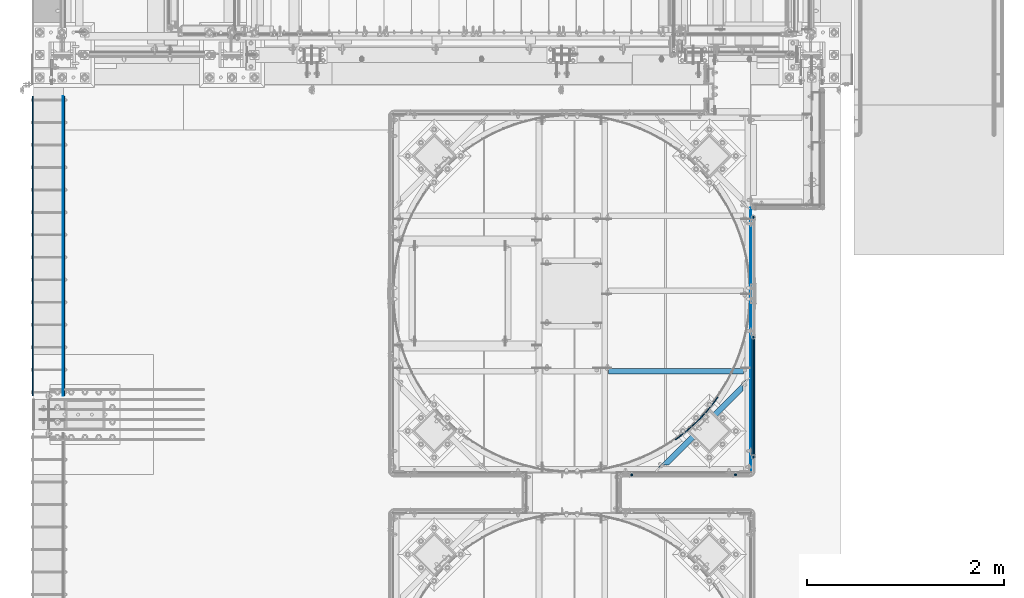
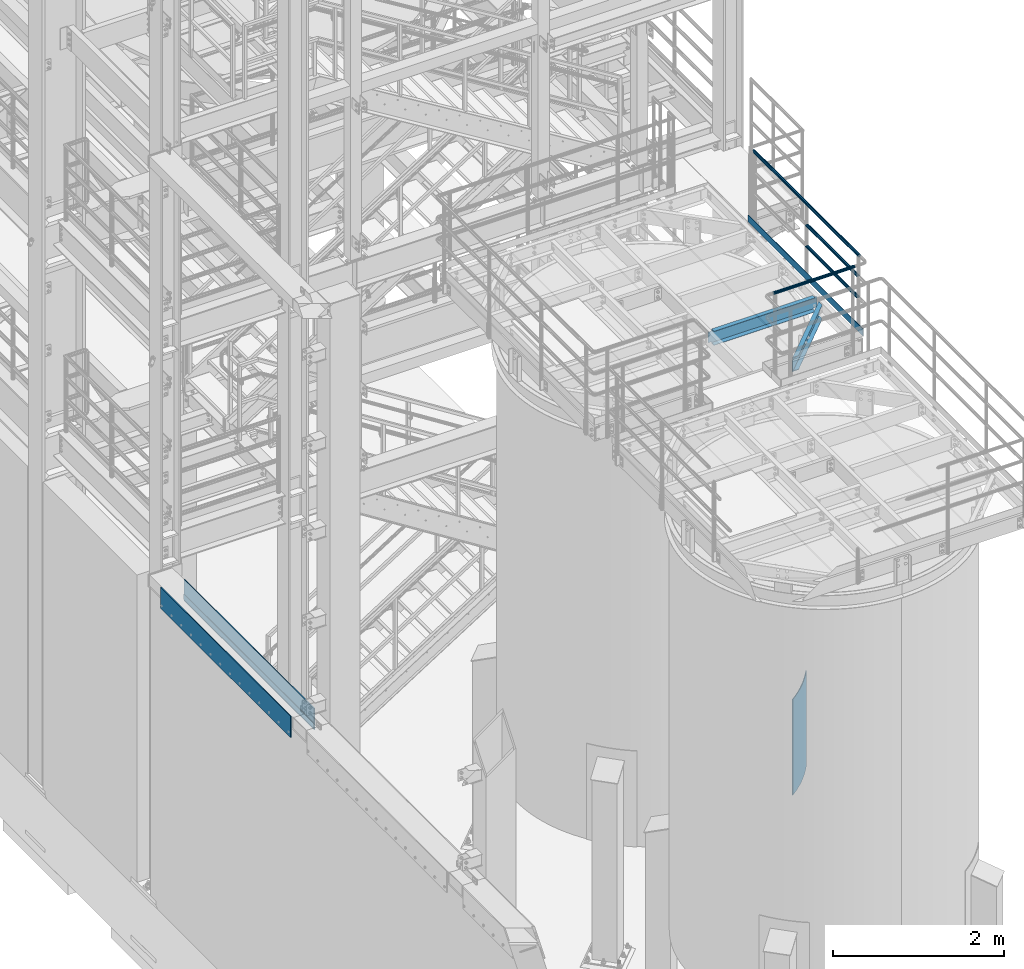
# One storey, part 928 of 1876: 11 beams, 7 elements without a shape of their own.
"""IFC2X3 building model written with IfcOpenShell, lengths in millimetres."""

from ifc_helpers import new_model, si_unit, frame, origin_with_axes, place, context, subcontext, project, spatial, faceted_brep, material, type_object, element, aggregate, save


model = new_model("IFC2X3")

# Units and contexts
model_context = context("Model", 3, precision=1e-05, world=origin_with_axes())
body_context = subcontext(model_context, "Body", "Model", "MODEL_VIEW")
ifc_project = project(units=[si_unit("LENGTHUNIT", "METRE", prefix="MILLI"), si_unit("AREAUNIT", "SQUARE_METRE"), si_unit("VOLUMEUNIT", "CUBIC_METRE"), si_unit("MASSUNIT", "GRAM", prefix="KILO"), si_unit("TIMEUNIT", "SECOND"), si_unit("PLANEANGLEUNIT", "RADIAN"), si_unit("SOLIDANGLEUNIT", "STERADIAN"), si_unit("THERMODYNAMICTEMPERATUREUNIT", "DEGREE_CELSIUS"), si_unit("LUMINOUSINTENSITYUNIT", "LUMEN")], contexts=[model_context])

# Site, building, storey
site_placement = place(None, origin_with_axes())
site = spatial("IfcSite", under=ifc_project, at=site_placement, CompositionType="ELEMENT")
building_placement = place(site_placement, origin_with_axes())
building = spatial("IfcBuilding", under=site, at=building_placement, Name="Undefined", CompositionType="ELEMENT")
storey_placement = place(building_placement, origin_with_axes())
storey = spatial("IfcBuildingStorey", under=building, at=storey_placement, Name="Undefined", CompositionType="ELEMENT", Elevation=0.0)

# Assembly, beam
assembly_1_placement = place(storey_placement, origin_with_axes())
assembly_1 = element("IfcElementAssembly", 1, at=assembly_1_placement, inside=storey, Name="PLATE", AssemblyPlace="NOTDEFINED", PredefinedType="RIGID_FRAME")
ifc_material_1 = material(Name="STEEL/A36")
beam_type_1 = type_object("IfcBeamType", PredefinedType="NOTDEFINED")
beam_1_placement = place(assembly_1_placement, frame((8.73150000000262, -7531.1, 4432.3), z_axis=(0.0, 0.0, 1.0), x_axis=(0.0, -1.0, 0.0)))
beam_1 = element("IfcBeam", 2, at=beam_1_placement, type_object=beam_type_1, material=ifc_material_1, Name="PLATE", context=body_context, shape_type="Brep", body=[
    faceted_brep([(0.0, 3.969, -38.1000000000004), (0.0, 3.969, 38.1000000000004), (3048.0, 3.969, 38.1000000000004), (3048.0, 3.969, -38.1000000000004), (0.0, -3.969, 38.1000000000004), (3048.0, -3.969, 38.1000000000004), (0.0, -3.969, -38.1000000000004), (3048.0, -3.969, -38.1000000000004)], [[[0, 1, 2, 3]], [[1, 4, 5, 2]], [[4, 6, 7, 5]], [[6, 0, 3, 7]], [[5, 7, 3, 2]], [[6, 4, 1, 0]]]),
])

assembly_2_placement = place(storey_placement, origin_with_axes())
assembly_2 = element("IfcElementAssembly", 3, at=assembly_2_placement, inside=storey, Name="BEAM", AssemblyPlace="NOTDEFINED", PredefinedType="RIGID_FRAME")
beam_type_2 = type_object("IfcBeamType", PredefinedType="NOTDEFINED")
beam_2_placement = place(assembly_2_placement, frame((-298.449999999997, -7531.1, 4521.2), z_axis=(0.0, 0.0, 1.0), x_axis=(0.0, -1.0, 0.0)))
beam_2 = element("IfcBeam", 4, at=beam_2_placement, type_object=beam_type_2, material=ifc_material_1, Name="PLATE", context=body_context, shape_type="Brep", body=[
    faceted_brep([(0.0, 6.35000000000002, -152.4), (0.0, 6.35000000000002, 152.4), (3048.00000152588, 6.35000000000002, 152.4), (3048.00000152588, 6.35000000000002, -152.4), (0.0, -6.35000000000002, 152.4), (3048.00000152588, -6.35000000000002, 152.4), (0.0, -6.35000000000002, -152.4), (3048.00000152588, -6.35000000000002, -152.4)], [[[0, 1, 2, 3]], [[1, 4, 5, 2]], [[4, 6, 7, 5]], [[6, 0, 3, 7]], [[5, 7, 3, 2]], [[6, 4, 1, 0]]]),
])
aggregate(assembly_2, [beam_2])

# Beam
beam_3_placement = place(assembly_1_placement, frame((19.0500000000009, -7531.1, 4521.2), z_axis=(0.0, 0.0, 1.0), x_axis=(0.0, -1.0, 0.0)))
beam_3 = element("IfcBeam", 5, at=beam_3_placement, type_object=beam_type_2, material=ifc_material_1, Name="PLATE", context=body_context, shape_type="Brep", body=[
    faceted_brep([(0.0, 6.35000000000002, -152.4), (0.0, 6.35000000000002, 152.4), (3048.00000152588, 6.35000000000002, 152.4), (3048.00000152588, 6.35000000000002, -152.4), (0.0, -6.35000000000002, 152.4), (3048.00000152588, -6.35000000000002, 152.4), (0.0, -6.35000000000002, -152.4), (3048.00000152588, -6.35000000000002, -152.4)], [[[0, 1, 2, 3]], [[1, 4, 5, 2]], [[4, 6, 7, 5]], [[6, 0, 3, 7]], [[5, 7, 3, 2]], [[6, 4, 1, 0]]]),
])

aggregate(assembly_1, [beam_1, beam_3])

# Assembly, beam
assembly_3_placement = place(storey_placement, origin_with_axes())
assembly_3 = element("IfcElementAssembly", 6, at=assembly_3_placement, inside=storey, Name="HANDRAIL", AssemblyPlace="NOTDEFINED", PredefinedType="RIGID_FRAME")
ifc_material_2 = material()
beam_type_3 = type_object("IfcBeamType", Name="PIPE1-1/4STD", PredefinedType="NOTDEFINED")
beam_4_placement = place(assembly_3_placement, frame((5770.12274593762, -11381.1963554687, 9090.025), z_axis=(0.0, 0.0, -1.0), x_axis=(1.0, 0.0, 0.0)))
beam_4 = element("IfcBeam", 7, at=beam_4_placement, type_object=beam_type_3, material=ifc_material_2, Name="HANDRAIL", ObjectType="PIPE1-1/4STD", context=body_context, shape_type="Brep", body=[
    faceted_brep([(0.0, -17.5259999999998, 0.0), (0.0, -15.1779612267264, 8.76300000000083), (1096.264, -15.1779612267255, 8.76300000000083), (1096.264, -17.5259999999998, 0.0), (0.0, -8.76299999999992, 15.1779612267255), (1096.264, -8.76300000000083, 15.1779612267255), (0.0, 0.0, 17.5259999999998), (1096.264, 0.0, 17.5259999999998), (0.0, 8.76299999999992, 15.1779612267255), (1096.264, 8.76300000000083, 15.1779612267255), (0.0, 15.1779612267264, 8.76300000000083), (1096.264, 15.1779612267255, 8.76300000000083), (0.0, 17.5259999999998, 0.0), (1096.264, 17.5259999999998, 0.0), (0.0, 15.1779612267264, -8.76300000000083), (1096.264, 15.1779612267255, -8.76300000000083), (0.0, 8.76299999999992, -15.1779612267255), (1096.264, 8.76300000000083, -15.1779612267255), (0.0, 0.0, -17.5259999999998), (1096.264, 0.0, -17.5259999999998), (0.0, -8.76299999999992, -15.1779612267255), (1096.264, -8.76300000000083, -15.1779612267255), (0.0, -15.1779612267264, -8.76300000000083), (1096.264, -15.1779612267255, -8.76300000000083), (9.09494701772928e-13, -21.0820000000003, 0.0), (0.0, -18.2575475625836, -10.5409999999993), (1096.264, -18.2575475625836, -10.5409999999993), (1096.264, -21.0820000000003, 0.0), (0.0, -10.5410000000002, -18.2575475625836), (1096.264, -10.5409999999993, -18.2575475625836), (-4.28826751885936e-09, 0.0, -21.0820000000003), (1096.264, 0.0, -21.0820000000003), (0.0, 10.5410000000002, -18.2575475625836), (1096.264, 10.5409999999993, -18.2575475625836), (0.0, 18.2575475625836, -10.5409999999993), (1096.264, 18.2575475625836, -10.5409999999993), (9.09494701772928e-13, 21.0820000000003, 0.0), (1096.264, 21.0820000000003, 0.0), (0.0, 18.2575475625836, 10.5409999999993), (1096.264, 18.2575475625836, 10.5409999999993), (0.0, 10.5410000000002, 18.2575475625836), (1096.264, 10.5409999999993, 18.2575475625836), (0.0, 0.0, 21.0820000000003), (1096.264, 0.0, 21.0820000000003), (0.0, -10.5410000000002, 18.2575475625836), (1096.264, -10.5409999999993, 18.2575475625836), (0.0, -18.2575475625836, 10.5409999999993), (1096.264, -18.2575475625836, 10.5409999999993)], [[[0, 1, 2, 3]], [[1, 4, 5, 2]], [[4, 6, 7, 5]], [[6, 8, 9, 7]], [[8, 10, 11, 9]], [[10, 12, 13, 11]], [[12, 14, 15, 13]], [[14, 16, 17, 15]], [[16, 18, 19, 17]], [[18, 20, 21, 19]], [[20, 22, 23, 21]], [[22, 0, 3, 23]], [[24, 25, 26, 27]], [[25, 28, 29, 26]], [[28, 30, 31, 29]], [[30, 32, 33, 31]], [[32, 34, 35, 33]], [[34, 36, 37, 35]], [[36, 38, 39, 37]], [[38, 40, 41, 39]], [[40, 42, 43, 41]], [[42, 44, 45, 43]], [[44, 46, 47, 45]], [[46, 24, 27, 47]], [[29, 31, 33, 35, 37, 39, 41, 43, 45, 47, 27, 26], [5, 7, 9, 11, 13, 15, 17, 19, 21, 23, 3, 2]], [[46, 44, 42, 40, 38, 36, 34, 32, 30, 28, 25, 24], [22, 20, 18, 16, 14, 12, 10, 8, 6, 4, 1, 0]]]),
])
aggregate(assembly_3, [beam_4])

# Assembly, beams
assembly_4_placement = place(storey_placement, origin_with_axes())
assembly_4 = element("IfcElementAssembly", 8, at=assembly_4_placement, inside=storey, Name="HANDRAIL", AssemblyPlace="NOTDEFINED", PredefinedType="RIGID_FRAME")
beam_5_placement = place(assembly_4_placement, frame((7025.13388293519, -11201.3643554687, 8480.425), z_axis=(0.0, 0.0, 1.0), x_axis=(0.0, 1.0, 0.0)))
beam_5 = element("IfcBeam", 9, at=beam_5_placement, type_object=beam_type_3, material=ifc_material_2, Name="RAIL", ObjectType="PIPE1-1/4STD", context=body_context, shape_type="Brep", body=[
    faceted_brep([(1200.94245243742, -10.5409999999993, 18.2575475625836), (1200.94245243742, -10.5409999999993, 13.3999612267253), (1200.46603877327, -8.76300000000083, 15.1779612267255), (1198.118, 0.0, 17.5259999999998), (1198.118, 0.0, 21.0820000000003), (1200.46603877327, 8.76300000000083, 15.1779612267255), (1200.94245243742, 10.5409999999993, 13.3999612267253), (1200.94245243742, 10.5409999999993, 18.2575475625836), (1219.2, 21.0820000000003, 0.0), (1208.659, 18.2575475625836, 10.5409999999993), (1208.659, 18.2575475625836, -10.5409999999993), (1205.57941366414, 15.1779612267255, 8.76300000000083), (1207.92745243742, 17.5259999999998, 0.0), (1205.57941366414, 15.1779612267255, -8.76300000000083), (1200.94245243742, 10.5409999999993, -13.3999612267253), (1200.94245243742, 10.5409999999993, -18.2575475625836), (1200.46603877327, 8.76300000000083, -15.1779612267255), (1198.118, 0.0, -17.5259999999998), (1198.118, 0.0, -21.0820000000003), (1200.94245243742, -10.5409999999993, -13.3999612267253), (1200.94245243742, -10.5409999999993, -18.2575475625836), (1200.46603877327, -8.76300000000083, -15.1779612267255), (1219.2, -21.0820000000003, 0.0), (1208.659, -18.2575475625836, -10.5409999999993), (1208.659, -18.2575475625836, 10.5409999999993), (1205.57941366414, -15.1779612267255, -8.76300000000083), (1207.92745243742, -17.5259999999998, 0.0), (1205.57941366414, -15.1779612267255, 8.76300000000083), (10.5409999957128, -18.2575475672238, -10.5409999999993), (18.2575475625817, -10.5410000000011, -18.2575475625836), (9.09494701772928e-13, 21.0820000000003, 0.0), (10.5409999957128, 18.2575475579433, -10.5409999999993), (10.5409999999983, 18.2575475625836, 10.5410000000011), (18.2575475625817, 10.5409999999993, 18.2575475625836), (21.0819999999985, 1.81898940354586e-12, 21.0820000000003), (18.2575475625817, 10.5409999999993, -18.2575475625836), (21.0819999999985, 0.0, -21.0819999999985), (21.0819999999985, 0.0, -17.5259999999998), (18.2575475625817, -10.5409999999974, -13.3999612267271), (18.7339612267233, -8.76300000000083, -15.1779612267255), (18.7339612267251, 8.76299999999901, -15.1779612267255), (18.2575475625817, 10.5410000000011, -13.3999612267235), (13.6205863358573, 15.1779612267255, -8.76299999999901), (11.2725475625839, 17.5259999999998, 0.0), (13.6205863358573, 15.1779612267255, 8.76300000000083), (18.2575475625817, 10.5410000000011, 13.3999612267253), (18.7339612267251, 8.76299999999901, 15.1779612267273), (21.0819999999985, 1.81898940354586e-12, 17.5259999999998), (18.7339612267233, -8.76300000000083, 15.1779612267273), (18.2575475625817, -10.5409999999974, 13.3999612267289), (18.2575475625817, -10.5410000000011, 18.2575475625836), (10.5409999999983, -18.2575475625836, 10.5410000000011), (9.09494701772928e-13, -21.0820000000003, 0.0), (13.6205863358537, -15.1779612267255, 8.76300000000083), (11.2725475625793, -17.5259999999998, 0.0), (13.6205863358537, -15.1779612267255, -8.76299999999901)], [[[0, 1, 2, 3, 4]], [[4, 3, 5, 6, 7]], [[8, 9, 10]], [[7, 6, 11, 12, 13, 14, 15, 10, 9]], [[16, 17, 18, 15, 14]], [[19, 20, 18, 17, 21]], [[22, 23, 24]], [[24, 23, 20, 19, 25, 26, 27, 1, 0]], [[28, 29, 20, 23]], [[30, 31, 32]], [[33, 34, 4, 7]], [[32, 33, 7, 9]], [[30, 32, 9, 8]], [[31, 30, 8, 10]], [[35, 31, 10, 15]], [[36, 35, 15, 18]], [[29, 36, 18, 20]], [[37, 36, 29, 38, 39]], [[40, 41, 35, 36, 37]], [[32, 31, 35, 41, 42, 43, 44, 45, 33]], [[33, 45, 46, 47, 34]], [[34, 47, 48, 49, 50]], [[34, 50, 0, 4]], [[50, 51, 24, 0]], [[51, 52, 22, 24]], [[52, 28, 23, 22]], [[51, 28, 52]], [[50, 49, 53, 54, 55, 38, 29, 28, 51]], [[55, 54, 26, 25]], [[21, 39, 38, 55, 25, 19]], [[37, 39, 21, 17]], [[40, 37, 17, 16]], [[42, 41, 40, 16, 14, 13]], [[43, 42, 13, 12]], [[44, 43, 12, 11]], [[5, 46, 45, 44, 11, 6]], [[47, 46, 5, 3]], [[48, 47, 3, 2]], [[53, 49, 48, 2, 1, 27]], [[54, 53, 27, 26]]]),
])
beam_6_placement = place(assembly_4_placement, frame((7025.13388293519, -9982.16435546873, 8785.225), z_axis=(0.0, 0.0, -1.0), x_axis=(0.0, -1.0, 0.0)))
beam_6 = element("IfcBeam", 10, at=beam_6_placement, type_object=beam_type_3, material=ifc_material_2, Name="RAIL", ObjectType="PIPE1-1/4STD", context=body_context, shape_type="Brep", body=[
    faceted_brep([(9.09494701772928e-13, 21.0820000000003, 0.0), (10.5409999957128, 18.2575475579433, -10.5409999999993), (10.5409999999983, 18.2575475625836, 10.5410000000011), (10.5409999999983, -18.2575475625836, 10.5410000000011), (10.5409999957128, -18.2575475672238, -10.5409999999993), (9.09494701772928e-13, -21.0820000000003, 0.0), (18.2575475625817, -10.5410000000011, 18.2575475625836), (18.2575475625817, -10.5409999999974, 13.3999612267289), (13.6205863358537, -15.1779612267255, 8.76300000000083), (11.2725475625793, -17.5259999999998, 0.0), (13.6205863358537, -15.1779612267255, -8.76299999999901), (18.2575475625817, -10.5409999999974, -13.3999612267271), (18.2575475625817, -10.5410000000011, -18.2575475625836), (21.0819999999985, 0.0, -17.5259999999998), (21.0819999999985, 0.0, -21.0819999999985), (18.7339612267233, -8.76300000000083, -15.1779612267255), (18.7339612267251, 8.76299999999901, -15.1779612267255), (18.2575475625817, 10.5410000000011, -13.3999612267235), (18.2575475625817, 10.5409999999993, -18.2575475625836), (13.6205863358573, 15.1779612267255, -8.76299999999901), (11.2725475625839, 17.5259999999998, 0.0), (13.6205863358573, 15.1779612267255, 8.76300000000083), (18.2575475625817, 10.5410000000011, 13.3999612267253), (18.2575475625817, 10.5409999999993, 18.2575475625836), (18.7339612267251, 8.76299999999901, 15.1779612267273), (21.0819999999985, 1.81898940354586e-12, 17.5259999999998), (21.0819999999985, 1.81898940354586e-12, 21.0820000000003), (18.7339612267233, -8.76300000000083, 15.1779612267273), (1219.2, 21.0820000000003, 0.0), (1208.659, 18.2575475625836, -10.5409999999993), (1200.94245243742, 10.5409999999993, -18.2575475625836), (1219.2, -21.0820000000003, 0.0), (1208.659, -18.2575475625836, -10.5409999999993), (1208.659, -18.2575475625836, 10.5409999999993), (1200.94245243742, -10.5409999999993, 18.2575475625836), (1200.94245243742, -10.5409999999993, -18.2575475625836), (1198.118, 0.0, -21.0820000000003), (1200.46603877327, 8.76300000000083, -15.1779612267255), (1198.118, 0.0, -17.5259999999998), (1200.94245243742, 10.5409999999993, -13.3999612267253), (1200.94245243742, -10.5409999999993, -13.3999612267253), (1200.46603877327, -8.76300000000083, -15.1779612267255), (1205.57941366414, -15.1779612267255, -8.76300000000083), (1207.92745243742, -17.5259999999998, 0.0), (1205.57941366414, -15.1779612267255, 8.76300000000083), (1200.94245243742, -10.5409999999993, 13.3999612267253), (1200.46603877327, -8.76300000000083, 15.1779612267255), (1198.118, 0.0, 17.5259999999998), (1198.118, 0.0, 21.0820000000003), (1200.94245243742, 10.5409999999993, 18.2575475625836), (1208.659, 18.2575475625836, 10.5409999999993), (1200.94245243742, 10.5409999999993, 13.3999612267253), (1205.57941366414, 15.1779612267255, 8.76300000000083), (1207.92745243742, 17.5259999999998, 0.0), (1205.57941366414, 15.1779612267255, -8.76300000000083), (1200.46603877327, 8.76300000000083, 15.1779612267255)], [[[0, 1, 2]], [[3, 4, 5]], [[6, 7, 8, 9, 10, 11, 12, 4, 3]], [[13, 14, 12, 11, 15]], [[16, 17, 18, 14, 13]], [[2, 1, 18, 17, 19, 20, 21, 22, 23]], [[23, 22, 24, 25, 26]], [[26, 25, 27, 7, 6]], [[1, 0, 28, 29]], [[18, 1, 29, 30]], [[31, 32, 33]], [[6, 3, 33, 34]], [[3, 5, 31, 33]], [[5, 4, 32, 31]], [[4, 12, 35, 32]], [[12, 14, 36, 35]], [[14, 18, 30, 36]], [[37, 38, 36, 30, 39]], [[40, 35, 36, 38, 41]], [[33, 32, 35, 40, 42, 43, 44, 45, 34]], [[34, 45, 46, 47, 48]], [[26, 6, 34, 48]], [[2, 23, 49, 50]], [[23, 26, 48, 49]], [[0, 2, 50, 28]], [[28, 50, 29]], [[49, 51, 52, 53, 54, 39, 30, 29, 50]], [[48, 47, 55, 51, 49]], [[25, 24, 55, 47]], [[55, 24, 22, 21, 52, 51]], [[21, 20, 53, 52]], [[20, 19, 54, 53]], [[19, 17, 16, 37, 39, 54]], [[16, 13, 38, 37]], [[13, 15, 41, 38]], [[41, 15, 11, 10, 42, 40]], [[10, 9, 43, 42]], [[9, 8, 44, 43]], [[8, 7, 27, 46, 45, 44]], [[27, 25, 47, 46]]]),
])
beam_7_placement = place(assembly_4_placement, frame((7025.13388293519, -8741.88235546873, 9090.025), z_axis=(0.0, 0.0, -1.0), x_axis=(0.0, -1.0, 0.0)))
beam_7 = element("IfcBeam", 11, at=beam_7_placement, type_object=beam_type_3, material=ifc_material_2, Name="HANDRAIL", ObjectType="PIPE1-1/4STD", context=body_context, shape_type="Brep", body=[
    faceted_brep([(21.0819999957121, -17.5260000092794, 0.0), (29.8449999957129, -15.1779612398623, 8.76299999999901), (2480.564, -15.1779612267264, 8.76300000000083), (2480.564, -17.5259999999998, 0.0), (36.2599612224394, -8.76300001595973, 15.1779612267255), (2480.564, -8.76299999999992, 15.1779612267255), (38.6079999957128, -1.69929990079254e-08, 17.5259999999998), (2480.564, 0.0, 17.5259999999998), (36.2599612224385, 8.76299998404011, 15.1779612267255), (2480.564, 8.76299999999992, 15.1779612267255), (29.8449999957138, 15.1779612135888, 8.76299999999901), (2480.564, 15.1779612267264, 8.76300000000083), (21.0819999957121, 17.5259999907203, 0.0), (2480.564, 17.5259999999998, 0.0), (12.3189999957121, 15.1779612213031, -8.76300000000083), (2480.564, 15.1779612267264, -8.76300000000083), (5.90403876898654, 8.76299999740149, -15.1779612267255), (2480.564, 8.76299999999992, -15.1779612267255), (3.55599999571223, -1.56524038175121e-09, -17.5259999999998), (2480.564, 0.0, -17.5259999999998), (5.90403876898563, -8.76300000259835, -15.1779612267255), (2480.564, -8.76299999999992, -15.1779612267255), (12.3189999957121, -15.1779612321488, -8.76300000000083), (2480.564, -15.1779612267264, -8.76300000000083), (21.0819999957121, -21.0820000092799, 0.0), (10.5409999957128, -18.2575475672238, -10.5409999999993), (2480.564, -18.2575475625836, -10.5409999999993), (2480.564, -21.0820000000003, 0.0), (2.8244524331285, -10.5410000012434, -18.2575475625836), (2480.564, -10.5410000000002, -18.2575475625836), (-4.28826751885936e-09, 0.0, -21.0820000000003), (2480.564, 0.0, -21.0820000000003), (2.8244524331285, 10.5409999987578, -18.2575475625836), (2480.564, 10.5410000000002, -18.2575475625836), (10.5409999957128, 18.2575475579433, -10.5409999999993), (2480.564, 18.2575475625836, -10.5409999999993), (21.081999995713, 21.0819999907208, 0.0), (2480.564, 21.0820000000003, 0.0), (31.6229999957131, 18.2575475486638, 10.5409999999993), (2480.564, 18.2575475625836, 10.5409999999993), (39.3395475582975, 10.5409999826852, 18.2575475625836), (2480.564, 10.5410000000002, 18.2575475625836), (42.1639999957133, -1.85582393896766e-08, 21.0820000000003), (2480.564, 0.0, 21.0820000000003), (39.3395475582965, -10.541000017316, 18.2575475625836), (2480.564, -10.5410000000002, 18.2575475625836), (31.6229999957131, -18.2575475765025, 10.5409999999993), (2480.564, -18.2575475625836, 10.5409999999993)], [[[0, 1, 2, 3]], [[1, 4, 5, 2]], [[4, 6, 7, 5]], [[6, 8, 9, 7]], [[8, 10, 11, 9]], [[10, 12, 13, 11]], [[12, 14, 15, 13]], [[14, 16, 17, 15]], [[16, 18, 19, 17]], [[18, 20, 21, 19]], [[20, 22, 23, 21]], [[22, 0, 3, 23]], [[24, 25, 26, 27]], [[25, 28, 29, 26]], [[28, 30, 31, 29]], [[30, 32, 33, 31]], [[32, 34, 35, 33]], [[34, 36, 37, 35]], [[36, 38, 39, 37]], [[38, 40, 41, 39]], [[40, 42, 43, 41]], [[42, 44, 45, 43]], [[44, 46, 47, 45]], [[46, 24, 27, 47]], [[29, 31, 33, 35, 37, 39, 41, 43, 45, 47, 27, 26], [5, 7, 9, 11, 13, 15, 17, 19, 21, 23, 3, 2]], [[38, 36, 34, 32, 30, 28, 25, 24, 46, 44, 42, 40], [1, 0, 22, 20, 18, 16, 14, 12, 10, 8, 6, 4]]]),
])
beam_type_4 = type_object("IfcBeamType", PredefinedType="NOTDEFINED")
beam_8_placement = place(assembly_4_placement, frame((7000.87688293518, -11353.7643554687, 8080.375), z_axis=(0.0, 0.0, 1.0), x_axis=(0.0, 1.0, 0.0)))
beam_8 = element("IfcBeam", 12, at=beam_8_placement, type_object=beam_type_4, material=ifc_material_1, Name="PLATE", context=body_context, shape_type="Brep", body=[
    faceted_brep([(0.0, 3.17500000000018, -50.8000000000002), (0.0, 3.17500000000018, 50.8000000000002), (2690.33235546873, 3.17500000000018, 50.8000000000002), (2690.33235546873, 3.17500000000018, -50.8000000000002), (0.0, -3.17500000000018, 50.8000000000002), (2690.33235546873, -3.17500000000018, 50.8000000000002), (0.0, -3.17500000000018, -50.8000000000002), (2690.33235546873, -3.17500000000018, -50.8000000000002)], [[[0, 1, 2, 3]], [[1, 4, 5, 2]], [[4, 6, 7, 5]], [[6, 0, 3, 7]], [[5, 7, 3, 2]], [[6, 4, 1, 0]]]),
])
aggregate(assembly_4, [beam_8, beam_5, beam_6, beam_7])

# Assembly, beam
assembly_5_placement = place(storey_placement, origin_with_axes())
assembly_5 = element("IfcElementAssembly", 13, at=assembly_5_placement, inside=storey, Name="BEAM", AssemblyPlace="NOTDEFINED", PredefinedType="RIGID_FRAME")
beam_type_5 = type_object("IfcBeamType", Name="C8X11.5", PredefinedType="NOTDEFINED")
beam_9_placement = place(assembly_5_placement, frame((6039.01386511981, -11369.8027447411, 7896.225), z_axis=(0.0, 0.0, 1.0), x_axis=(0.707106781186548, 0.707106781186547, 0.0)))
beam_9 = element("IfcBeam", 14, at=beam_9_placement, type_object=beam_type_5, material=ifc_material_1, Name="BEAM", ObjectType="C8X11.5", context=body_context, shape_type="Brep", body=[
    faceted_brep([(154.529650862243, -28.5750000000025, 101.6), (154.529650862243, -28.5750000000025, 96.8355949999996), (1223.93966372519, -28.5750000000044, 96.8355949999996), (1223.93966372519, -28.5750000000044, 101.6), (92.6423292584636, 22.225000000004, 77.1667299225874), (86.2923292584624, 28.5750000000062, 77.1667299225874), (79.4191388898289, 28.5750000000062, 76.1999999999998), (85.7691388898302, 22.225000000004, 76.1999999999998), (98.4691386990994, 22.225000000004, 79.9197438230658), (92.119138699099, 28.5750000000062, 79.9197438230658), (102.362488294559, 22.225000000004, 84.0399202912195), (96.0124882945579, 28.5750000000062, 84.0399202912195), (106.897026668147, 19.0576241940926, 88.899999809265), (97.3796508622331, 28.5750000000062, 88.899999809265), (103.581210715098, 22.225000000004, 88.3723149999996), (1274.88810387234, 22.2250000000049, 88.3723149999996), (1271.57228791927, 19.0576241940789, 88.8999998092668), (97.3796508622331, 28.5750000000062, 101.6), (1292.70017569896, 22.225000000004, -76.1999999999971), (1299.05017569896, 28.5750000000053, -76.1999999999971), (1319.3218385947, 28.5750000000053, -76.1999999999971), (1319.3218385947, 22.225000000004, -76.1999999999971), (1285.82698533033, 22.2250000000049, -77.1667299225846), (1292.17698533033, 28.5750000000062, -77.1667299225846), (1280.00017588969, 22.2250000000049, -79.9197438230631), (1286.35017588969, 28.5750000000062, -79.9197438230631), (1276.10682629423, 22.2250000000031, -84.0399202912167), (1282.45682629424, 28.5750000000044, -84.0399202912167), (1274.88810387369, 22.225000000004, -88.3723149999996), (1271.57228792066, 19.0576241941089, -88.8999998092622), (1281.08966372656, 28.5750000000062, -88.8999998092622), (103.581210715046, 22.225000000004, -88.3723149999996), (106.897026668097, 19.0576241940926, -88.899999809265), (154.529650862193, -28.5750000000044, -96.8355949999996), (1223.93966372655, -28.5750000000035, -96.8355949999996), (154.529650862193, -28.5750000000044, -101.6), (1223.93966372655, -28.5750000000035, -101.6), (1281.08966372656, 28.5750000000062, -101.6), (97.3796508621845, 28.5750000000044, -101.6), (97.3796508621845, 28.5750000000044, -88.899999809265), (102.362488294509, 22.225000000004, -84.0399202912195), (96.0124882945074, 28.5750000000062, -84.0399202912195), (98.4691386990489, 22.2250000000058, -79.9197438230658), (92.1191386990495, 28.5750000000044, -79.9197438230658), (92.6423292584141, 22.225000000004, -77.1667299225874), (86.2923292584137, 28.5750000000044, -77.1667299225874), (85.7691388897797, 22.225000000004, -76.1999999999998), (79.4191388897784, 28.5750000000062, -76.1999999999998), (58.5960695783419, 22.2250000000058, -76.1999999999998), (58.5960695783419, 28.5750000000044, -76.1999999999998), (1281.0896637252, 28.5750000000053, 101.6), (1281.0896637252, 28.5750000000053, 88.8999998092668), (1282.45682629288, 28.5750000000044, 84.0399202912213), (1286.35017588834, 28.5750000000053, 79.9197438230676), (1292.17698532897, 28.5750000000053, 77.1667299225892), (1299.0501756976, 28.5750000000053, 76.2000000000016), (1319.3218385947, 28.5750000000053, 76.2000000000016), (58.5960695783419, 28.5750000000044, 76.1999999999998), (58.5960695783419, 22.2250000000058, 76.1999999999998), (1319.3218385947, 22.225000000004, 76.2000000000016), (1292.7001756976, 22.2250000000049, 76.2000000000016), (1285.82698532897, 22.225000000004, 77.1667299225892), (1280.00017588834, 22.225000000004, 79.9197438230676), (1276.10682629288, 22.225000000004, 84.0399202912213)], [[[0, 1, 2, 3]], [[4, 5, 6, 7]], [[8, 9, 5, 4]], [[10, 11, 9, 8]], [[12, 13, 11, 10, 14]], [[2, 1, 12, 14, 15, 16]], [[0, 17, 13, 12, 1]], [[18, 19, 20, 21]], [[19, 18, 22, 23]], [[23, 22, 24, 25]], [[25, 24, 26, 27]], [[27, 26, 28, 29, 30]], [[31, 32, 33, 34, 29, 28]], [[33, 35, 36, 34]], [[30, 29, 34, 36, 37]], [[35, 38, 37, 36]], [[33, 32, 39, 38, 35]], [[31, 40, 41, 39, 32]], [[42, 43, 41, 40]], [[44, 45, 43, 42]], [[46, 47, 45, 44]], [[47, 46, 48, 49]], [[6, 5, 9, 11, 13, 17, 50, 51, 52, 53, 54, 55, 56, 20, 19, 23, 25, 27, 30, 37, 38, 39, 41, 43, 45, 47, 49, 57]], [[7, 6, 57, 58]], [[49, 48, 58, 57]], [[46, 44, 42, 40, 31, 28, 26, 24, 22, 18, 21, 59, 60, 61, 62, 63, 15, 14, 10, 8, 4, 7, 58, 48]], [[20, 56, 59, 21]], [[55, 60, 59, 56]], [[54, 61, 60, 55]], [[53, 62, 61, 54]], [[52, 63, 62, 53]], [[51, 16, 15, 63, 52]], [[50, 3, 2, 16, 51]], [[17, 0, 3, 50]]]),
])
aggregate(assembly_5, [beam_9])

assembly_6_placement = place(storey_placement, origin_with_axes())
assembly_6 = element("IfcElementAssembly", 15, at=assembly_6_placement, inside=storey, Name="BEAM", AssemblyPlace="NOTDEFINED", PredefinedType="RIGID_FRAME")
beam_10_placement = place(assembly_6_placement, frame((5486.40333884985, -10328.2393554687, 7896.225), z_axis=(0.0, 0.0, 1.0), x_axis=(1.0, 0.0, 0.0)))
beam_10 = element("IfcBeam", 16, at=beam_10_placement, type_object=beam_type_5, material=ifc_material_1, Name="BEAM", ObjectType="C8X11.5", context=body_context, shape_type="Brep", body=[
    faceted_brep([(19.0499999999993, 22.2250000000004, -76.2000000000007), (19.0499999999993, 28.5750000000007, -76.2000000000007), (57.1500001907361, 28.5750000000007, -76.2000000000007), (57.1500001907361, 22.2250000000004, -76.2000000000007), (62.0100797087816, 28.5750000000007, -77.1667299225883), (62.0100797087816, 22.2250000000004, -77.1667299225883), (66.1302561769353, 28.5750000000007, -79.9197438230667), (66.1302561769353, 22.2250000000004, -79.9197438230667), (68.8832700774137, 28.5750000000007, -84.0399202912204), (68.8832700774137, 22.2250000000004, -84.0399202912204), (69.8500000000013, 19.0576241940817, -88.8999998092659), (69.8500000000013, 28.5750000000007, -88.8999998092659), (69.8500000000013, 28.5750000000007, -101.6), (69.8500000000013, -28.5750000000007, -101.6), (69.8500000000013, -28.5750000000007, -96.8355949999996), (69.7450369653598, 22.2250000000004, -88.3723149999996), (1441.44713699756, -28.5750000000007, -96.8355949999996), (1441.44713699756, -28.5750000000007, -101.6), (1441.44713699756, 28.5750000000007, -101.6), (1441.44713699756, 28.5750000000007, -88.899999809264), (1441.44713699756, 19.0576241940926, -88.899999809264), (1441.44713699756, -28.5750000000007, 96.8355949999996), (1441.44713699756, -28.5750000000007, 101.6), (69.8500000000013, -28.5750000000007, 101.6), (69.8500000000013, -28.5750000000007, 96.8355949999996), (1441.44713699756, 19.0576241940817, 88.8999998092659), (1441.44713699756, 28.5750000000007, 88.8999998092659), (1441.44713699756, 28.5750000000007, 101.6), (69.8500000000013, 28.5750000000007, 101.6), (57.1500001907361, 22.2250000000004, 76.1999999999989), (57.1500001907361, 28.5750000000007, 76.1999999999989), (19.0499999999993, 28.5750000000007, 76.1999999999989), (19.0499999999993, 22.2250000000004, 76.1999999999989), (62.0100797087816, 22.2250000000004, 77.1667299225865), (62.0100797087816, 28.5750000000007, 77.1667299225865), (66.1302561769353, 22.2250000000004, 79.9197438230649), (66.1302561769353, 28.5750000000007, 79.9197438230649), (68.8832700774137, 22.2250000000004, 84.0399202912186), (68.8832700774137, 28.5750000000007, 84.0399202912186), (69.8500000000013, 19.0576241940926, 88.899999809264), (69.8500000000013, 28.5750000000007, 88.899999809264), (69.7450369653607, 22.2250000000004, 88.3723149999996), (1441.5521000322, 22.2250000000004, 88.3723149999996), (1442.41386692015, 22.2250000000004, 84.0399202912204), (1442.41386692015, 28.5750000000007, 84.0399202912204), (1445.16688082063, 22.2250000000004, 79.9197438230667), (1445.16688082063, 28.5750000000007, 79.9197438230667), (1449.28705728878, 22.2250000000004, 77.1667299225883), (1449.28705728878, 28.5750000000007, 77.1667299225883), (1454.14713680683, 22.2250000000004, 76.2000000000007), (1454.14713680683, 28.5750000000007, 76.2000000000007), (1492.24713699756, 22.2250000000004, 76.2000000000007), (1492.24713699756, 28.5750000000007, 76.2000000000007), (1492.24713699756, 22.2250000000004, -76.1999999999989), (1492.24713699756, 28.5750000000007, -76.1999999999989), (1454.14713680683, 22.2250000000004, -76.1999999999989), (1454.14713680683, 28.5750000000007, -76.1999999999989), (1449.28705728878, 22.2250000000004, -77.1667299225865), (1449.28705728878, 28.5750000000007, -77.1667299225865), (1445.16688082063, 22.2250000000004, -79.9197438230649), (1445.16688082063, 28.5750000000007, -79.9197438230649), (1442.41386692015, 22.2250000000004, -84.0399202912186), (1442.41386692015, 28.5750000000007, -84.0399202912186), (1441.5521000322, 22.2250000000004, -88.3723149999996)], [[[0, 1, 2, 3]], [[3, 2, 4, 5]], [[5, 4, 6, 7]], [[7, 6, 8, 9]], [[10, 11, 12, 13, 14]], [[15, 9, 8, 11, 10]], [[16, 17, 18, 19, 20]], [[21, 22, 23, 24]], [[22, 21, 25, 26, 27]], [[22, 27, 28, 23]], [[29, 30, 31, 32]], [[33, 34, 30, 29]], [[35, 36, 34, 33]], [[37, 38, 36, 35]], [[39, 40, 38, 37, 41]], [[23, 28, 40, 39, 24]], [[41, 42, 25, 21, 24, 39]], [[43, 44, 26, 25, 42]], [[45, 46, 44, 43]], [[47, 48, 46, 45]], [[49, 50, 48, 47]], [[51, 52, 50, 49]], [[52, 51, 53, 54]], [[53, 55, 56, 54]], [[57, 58, 56, 55]], [[59, 60, 58, 57]], [[61, 62, 60, 59]], [[63, 20, 19, 62, 61]], [[14, 16, 20, 63, 15, 10]], [[17, 16, 14, 13]], [[18, 17, 13, 12]], [[6, 4, 2, 1, 31, 30, 34, 36, 38, 40, 28, 27, 26, 44, 46, 48, 50, 52, 54, 56, 58, 60, 62, 19, 18, 12, 11, 8]], [[32, 31, 1, 0]], [[63, 61, 59, 57, 55, 53, 51, 49, 47, 45, 43, 42, 41, 37, 35, 33, 29, 32, 0, 3, 5, 7, 9, 15]]]),
])
aggregate(assembly_6, [beam_10])

assembly_7_placement = place(storey_placement, origin_with_axes())
assembly_7 = element("IfcElementAssembly", 17, at=assembly_7_placement, inside=storey, Name="COLUMN", AssemblyPlace="NOTDEFINED", PredefinedType="RIGID_FRAME")
beam_type_6 = type_object("IfcBeamType", PredefinedType="NOTDEFINED")
beam_11_placement = place(assembly_7_placement, frame((6234.79283509037, -11023.0721979111, 2209.8), z_axis=(0.0, 0.0, 1.0), x_axis=(0.707106781186548, 0.707106781186547, 0.0)))
beam_11 = element("IfcBeam", 18, at=beam_11_placement, type_object=beam_type_6, material=ifc_material_1, Name="PLATE", context=body_context, shape_type="Brep", body=[
    faceted_brep([(0.79930179960138, 4.69494652612411, -685.8), (0.79930179960138, 4.69494652612411, 685.8), (61.342263906226, -4.5647055990521, 685.8), (61.342263906226, -4.5647055990521, -685.8), (-0.799301799600926, -4.69494652612411, 685.8), (-0.799301799600926, -4.69494652612411, -685.8), (60.0611937621738, -14.003163327201, -685.8), (60.0611937621738, -14.003163327201, 685.8), (122.16302969072, -11.7776015161726, 685.8), (122.16302969072, -11.7776015161726, -685.8), (121.200950016122, -21.2538891700879, -685.8), (121.200950016122, -21.2538891700879, 685.8), (183.192425169105, -16.9355376990206, 685.8), (183.192425169105, -16.9355376990206, -685.8), (182.550430177147, -26.438877503022, -685.8), (182.550430177147, -26.438877503022, 685.8), (244.361039074185, -20.0326478124662, 685.8), (244.361039074185, -20.0326478124662, -685.8), (244.039858932445, -29.5522312233406, -685.8), (244.039858932445, -29.5522312233406, 685.8), (305.59930179986, -21.0654093844969, 685.8), (305.59930179986, -21.0654093844969, -685.8), (305.599301799861, -30.5904093844983, -685.8), (305.599301799861, -30.5904093844983, 685.8), (366.837564525536, -20.0326478124662, 685.8), (366.837564525536, -20.0326478124662, -685.8), (367.158744667275, -29.5522312233406, -685.8), (367.158744667275, -29.5522312233406, 685.8), (428.006178430616, -16.9355376990206, 685.8), (428.006178430616, -16.9355376990206, -685.8), (428.648173422574, -26.438877503022, -685.8), (428.648173422574, -26.438877503022, 685.8), (489.035573909001, -11.7776015161708, 685.8), (489.035573909001, -11.7776015161708, -685.8), (489.997653583599, -21.253889170086, -685.8), (489.997653583599, -21.253889170086, 685.8), (549.856339693495, -4.5647055990521, 685.8), (549.856339693495, -4.5647055990521, -685.8), (551.137409837547, -14.003163327201, -685.8), (551.137409837547, -14.003163327201, 685.8), (610.39930180012, 4.69494652612411, 685.8), (610.39930180012, 4.69494652612411, -685.8), (611.997905399323, -4.69494652612229, 685.8), (611.997905399323, -4.69494652612229, -685.8)], [[[0, 1, 2, 3]], [[4, 5, 6, 7]], [[5, 4, 1, 0]], [[3, 2, 8, 9]], [[7, 6, 10, 11]], [[9, 8, 12, 13]], [[11, 10, 14, 15]], [[13, 12, 16, 17]], [[15, 14, 18, 19]], [[17, 16, 20, 21]], [[19, 18, 22, 23]], [[21, 20, 24, 25]], [[23, 22, 26, 27]], [[25, 24, 28, 29]], [[27, 26, 30, 31]], [[29, 28, 32, 33]], [[31, 30, 34, 35]], [[33, 32, 36, 37]], [[35, 34, 38, 39]], [[37, 36, 40, 41]], [[36, 32, 28, 24, 20, 16, 12, 8, 2, 1, 4, 7, 11, 15, 19, 23, 27, 31, 35, 39, 42, 40]], [[39, 38, 43, 42]], [[38, 34, 30, 26, 22, 18, 14, 10, 6, 5, 0, 3, 9, 13, 17, 21, 25, 29, 33, 37, 41, 43]], [[42, 43, 41, 40]]]),
])
aggregate(assembly_7, [beam_11])

save(model, "model.ifc")
